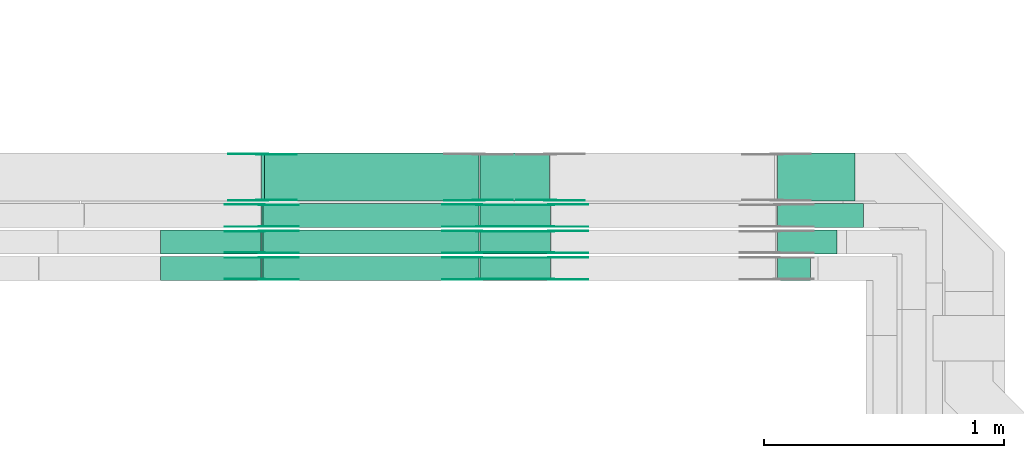
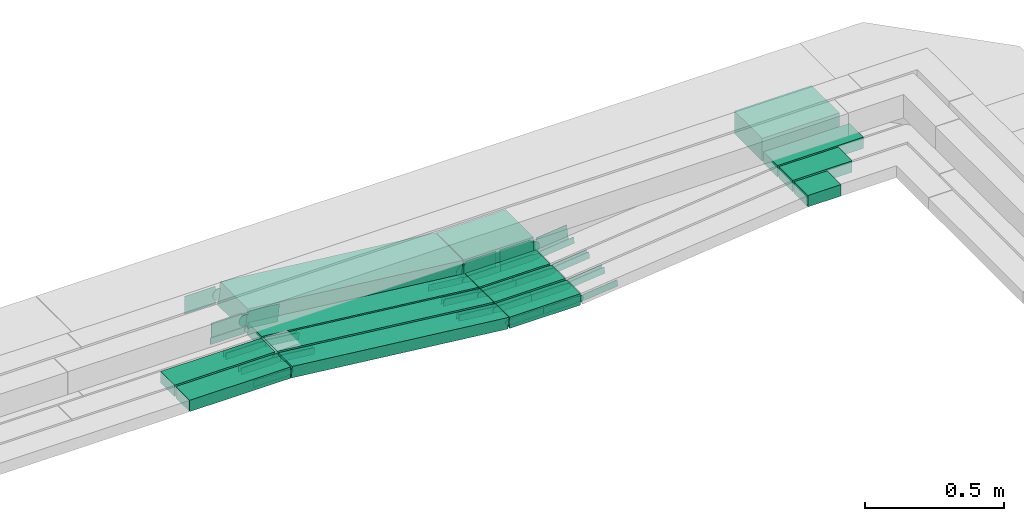
# One storey, part 18 of 32: 44 flow fittings, 14 flow segments.
"""IFC2X3 building model written with IfcOpenShell, lengths in millimetres."""

from ifc_helpers import new_model, entity, si_unit, converted_unit, derived_unit, direction, frame, frame_2d, origin, origin_2d_with_axis, place, context, subcontext, project, spatial, polyline, circle_curve, parameter, trimmed, segment, composite_curve, rectangle, outline, extrude, source, transform, mapped, material, type_object, type_shapes, element, save


model = new_model("IFC2X3")

# Units and contexts
model_context = context("Model", 3, precision=0.01, world=origin(), true_north=direction((6.12303176911189e-17, 1.0)))
body_context = subcontext(model_context, "Body", "Model", "MODEL_VIEW")
ifc_project = project(units=[si_unit("LENGTHUNIT", "METRE", prefix="MILLI"), si_unit("AREAUNIT", "SQUARE_METRE"), si_unit("VOLUMEUNIT", "CUBIC_METRE"), converted_unit("PLANEANGLEUNIT", "DEGREE", entity("IfcRatioMeasure", 0.0174532925199433), si_unit("PLANEANGLEUNIT", "RADIAN"), dimensions=[0, 0, 0, 0, 0, 0, 0]), si_unit("MASSUNIT", "GRAM", prefix="KILO"), derived_unit("MASSDENSITYUNIT", [(si_unit("MASSUNIT", "GRAM", prefix="KILO"), 1), (si_unit("LENGTHUNIT", "METRE"), -3)]), derived_unit("MOMENTOFINERTIAUNIT", [(si_unit("LENGTHUNIT", "METRE"), 4)]), si_unit("TIMEUNIT", "SECOND"), si_unit("FREQUENCYUNIT", "HERTZ"), si_unit("THERMODYNAMICTEMPERATUREUNIT", "DEGREE_CELSIUS"), derived_unit("THERMALTRANSMITTANCEUNIT", [(si_unit("MASSUNIT", "GRAM", prefix="KILO"), 1), (si_unit("THERMODYNAMICTEMPERATUREUNIT", "KELVIN"), -1), (si_unit("TIMEUNIT", "SECOND"), -3)]), derived_unit("VOLUMETRICFLOWRATEUNIT", [(si_unit("LENGTHUNIT", "METRE"), 3), (si_unit("TIMEUNIT", "SECOND"), -1)]), derived_unit("MASSFLOWRATEUNIT", [(si_unit("MASSUNIT", "GRAM", prefix="KILO"), 1), (si_unit("TIMEUNIT", "SECOND"), -1)]), derived_unit("ROTATIONALFREQUENCYUNIT", [(si_unit("TIMEUNIT", "SECOND"), -1)]), si_unit("ELECTRICCURRENTUNIT", "AMPERE"), si_unit("ELECTRICVOLTAGEUNIT", "VOLT"), si_unit("POWERUNIT", "WATT"), si_unit("FORCEUNIT", "NEWTON", prefix="KILO"), si_unit("ILLUMINANCEUNIT", "LUX"), si_unit("LUMINOUSFLUXUNIT", "LUMEN"), si_unit("LUMINOUSINTENSITYUNIT", "CANDELA"), derived_unit("USERDEFINED", [(si_unit("MASSUNIT", "GRAM", prefix="KILO"), -1), (si_unit("LENGTHUNIT", "METRE"), -2), (si_unit("TIMEUNIT", "SECOND"), 3), (si_unit("LUMINOUSFLUXUNIT", "LUMEN"), 1)]), derived_unit("LINEARVELOCITYUNIT", [(si_unit("LENGTHUNIT", "METRE"), 1), (si_unit("TIMEUNIT", "SECOND"), -1)]), si_unit("PRESSUREUNIT", "PASCAL"), derived_unit("USERDEFINED", [(si_unit("LENGTHUNIT", "METRE"), -2), (si_unit("MASSUNIT", "GRAM", prefix="KILO"), 1), (si_unit("TIMEUNIT", "SECOND"), -2)]), derived_unit("LINEARFORCEUNIT", [(si_unit("MASSUNIT", "GRAM", prefix="KILO"), 1), (si_unit("LENGTHUNIT", "METRE"), 1), (si_unit("TIMEUNIT", "SECOND"), -2), (si_unit("LENGTHUNIT", "METRE"), -1)]), derived_unit("PLANARFORCEUNIT", [(si_unit("MASSUNIT", "GRAM", prefix="KILO"), 1), (si_unit("LENGTHUNIT", "METRE"), 1), (si_unit("TIMEUNIT", "SECOND"), -2), (si_unit("LENGTHUNIT", "METRE"), -2)])], contexts=[model_context])

# Site, building, storey
site_placement = place(None, origin())
site = spatial("IfcSite", under=ifc_project, at=site_placement, CompositionType="ELEMENT")
building_placement = place(site_placement, origin())
building = spatial("IfcBuilding", under=site, at=building_placement, CompositionType="ELEMENT")
storey_placement = place(building_placement, frame((0.0, 0.0, 8100.0)))
storey = spatial("IfcBuildingStorey", under=building, at=storey_placement, CompositionType="ELEMENT", Elevation=8100.0)

# Flow segments
cable_carrier_segment_type = type_object("IfcCableCarrierSegmentType", PredefinedType="CABLETRAYSEGMENT")
flow_segment_1_placement = place(storey_placement, frame((42299.73, 9975.0, 2547.39)))
element("IfcFlowSegment", 1, at=flow_segment_1_placement, inside=storey, type_object=cable_carrier_segment_type, context=body_context, shape_type="SweptSolid", body=[
    extrude(rectangle(XDim=321.461786684155, YDim=200.000000000002, at=origin_2d_with_axis()), frame((160.73, 100.0, 0.0), z_axis=(0.0, 0.0, 1.0), x_axis=(-1.0, 0.0, 0.0)), (0.0, 0.0, 1.0), 99.9999999999989),
])
flow_segment_2_placement = place(storey_placement, frame((42299.91, 9865.0, 2544.96)))
element("IfcFlowSegment", 2, at=flow_segment_2_placement, inside=storey, type_object=cable_carrier_segment_type, context=body_context, shape_type="SweptSolid", body=[
    extrude(rectangle(XDim=357.279766558546, YDim=99.9999998664901, at=origin_2d_with_axis()), frame((178.64, 50.0, 0.02), z_axis=(0.000118881671848944, 0.0, 0.999999992933574), x_axis=(-0.999999992933574, 0.0, 0.000118881671848944)), (0.0, 0.0, 1.0), 49.9999999332506),
])
flow_segment_3_placement = place(storey_placement, frame((42299.73, 9755.0, 2546.32)))
element("IfcFlowSegment", 3, at=flow_segment_3_placement, inside=storey, type_object=cable_carrier_segment_type, context=body_context, shape_type="SweptSolid", body=[
    extrude(rectangle(XDim=247.461786684189, YDim=99.9999999999989, at=origin_2d_with_axis()), frame((123.73, 50.0, 0.0), z_axis=(0.0, 0.0, 1.0), x_axis=(-1.0, 0.0, 0.0)), (0.0, 0.0, 1.0), 50.0000000000016),
])
flow_segment_4_placement = place(storey_placement, frame((41059.78, 9645.0, 2446.67)))
element("IfcFlowSegment", 4, at=flow_segment_4_placement, inside=storey, type_object=cable_carrier_segment_type, context=body_context, shape_type="SweptSolid", body=[
    extrude(rectangle(XDim=294.865843634582, YDim=100.000000000001, at=origin_2d_with_axis()), frame((147.43, 50.0, 0.0), z_axis=(0.0, 0.0, 1.0), x_axis=(-1.0, 0.0, 0.0)), (0.0, 0.0, 1.0), 50.0000000000016),
])
flow_segment_5_placement = place(storey_placement, frame((42299.73, 9645.0, 2546.67)))
element("IfcFlowSegment", 5, at=flow_segment_5_placement, inside=storey, type_object=cable_carrier_segment_type, context=body_context, shape_type="SweptSolid", body=[
    extrude(rectangle(XDim=137.461786684197, YDim=100.000000000001, at=origin_2d_with_axis()), frame((68.73, 50.0, 0.0), z_axis=(0.0, 0.0, 1.0), x_axis=(-1.0, 0.0, 0.0)), (0.0, 0.0, 1.0), 49.9999999999995),
])
flow_segment_6_placement = place(storey_placement, frame((40151.55, 9645.0, 2447.11)))
element("IfcFlowSegment", 6, at=flow_segment_6_placement, inside=storey, type_object=cable_carrier_segment_type, context=body_context, shape_type="SweptSolid", body=[
    extrude(rectangle(XDim=50.0000000000012, YDim=100.000000000001, at=origin_2d_with_axis()), frame((2.74, 50.0, 124.24), z_axis=(0.993961132894519, 0.0, -0.109732703853703), x_axis=(0.109732703853703, 0.0, 0.993961132894519)), (0.0, 0.0, 1.0), 905.782469130237),
])
flow_segment_7_placement = place(storey_placement, frame((39730.39, 9645.0, 2546.63)))
element("IfcFlowSegment", 7, at=flow_segment_7_placement, inside=storey, type_object=cable_carrier_segment_type, context=body_context, shape_type="SweptSolid", body=[
    extrude(rectangle(XDim=418.730000005077, YDim=100.000000000001, at=origin_2d_with_axis()), frame((209.37, 50.0, 0.0), z_axis=(0.0, 0.0, 1.0), x_axis=(-1.0, 0.0, 0.0)), (0.0, 0.0, 1.0), 50.0000000000016),
])
flow_segment_8_placement = place(storey_placement, frame((41059.78, 9755.0, 2446.32)))
element("IfcFlowSegment", 8, at=flow_segment_8_placement, inside=storey, type_object=cable_carrier_segment_type, context=body_context, shape_type="SweptSolid", body=[
    extrude(rectangle(XDim=294.902694932285, YDim=99.9999999999989, at=origin_2d_with_axis()), frame((147.45, 50.0, 0.0), z_axis=(0.0, 0.0, 1.0), x_axis=(-1.0, 0.0, 0.0)), (0.0, 0.0, 1.0), 50.0000000000016),
])
flow_segment_9_placement = place(storey_placement, frame((40151.51, 9755.0, 2446.76)))
element("IfcFlowSegment", 9, at=flow_segment_9_placement, inside=storey, type_object=cable_carrier_segment_type, context=body_context, shape_type="SweptSolid", body=[
    extrude(rectangle(XDim=50.0000000000012, YDim=99.9999999999989, at=origin_2d_with_axis()), frame((2.74, 50.0, 124.25), z_axis=(0.993961132894519, 0.0, -0.109732703853703), x_axis=(0.109732703853703, 0.0, 0.993961132894519)), (0.0, 0.0, 1.0), 905.820480780093),
])
flow_segment_10_placement = place(storey_placement, frame((39730.39, 9755.0, 2546.29)))
element("IfcFlowSegment", 10, at=flow_segment_10_placement, inside=storey, type_object=cable_carrier_segment_type, context=body_context, shape_type="SweptSolid", body=[
    extrude(rectangle(XDim=418.692217902529, YDim=99.9999999999989, at=origin_2d_with_axis()), frame((209.35, 50.0, 0.0), z_axis=(0.0, 0.0, 1.0), x_axis=(-1.0, 0.0, 0.0)), (0.0, 0.0, 1.0), 50.0000000000038),
])
flow_segment_11_placement = place(storey_placement, frame((41059.6, 9865.0, 2444.98)))
element("IfcFlowSegment", 11, at=flow_segment_11_placement, inside=storey, type_object=cable_carrier_segment_type, context=body_context, shape_type="SweptSolid", body=[
    extrude(rectangle(XDim=295.052090595501, YDim=99.9999999999989, at=origin_2d_with_axis()), frame((147.53, 50.0, 0.0), z_axis=(0.0, 0.0, 1.0), x_axis=(-1.0, 0.0, 0.0)), (0.0, 0.0, 1.0), 50.0000000000016),
])
flow_segment_12_placement = place(storey_placement, frame((40151.55, 9865.0, 2445.42)))
element("IfcFlowSegment", 12, at=flow_segment_12_placement, inside=storey, type_object=cable_carrier_segment_type, context=body_context, shape_type="SweptSolid", body=[
    extrude(rectangle(XDim=50.0000000000012, YDim=99.9999999999989, at=origin_2d_with_axis()), frame((2.74, 50.0, 124.22), z_axis=(0.993961132894519, 0.0, -0.109732703853703), x_axis=(0.109732703853703, 0.0, 0.993961132894519)), (0.0, 0.0, 1.0), 905.595090615417),
])
flow_segment_13_placement = place(storey_placement, frame((41059.78, 9975.0, 2447.11)))
element("IfcFlowSegment", 13, at=flow_segment_13_placement, inside=storey, type_object=cable_carrier_segment_type, context=body_context, shape_type="SweptSolid", body=[
    extrude(rectangle(XDim=289.500216036665, YDim=199.999999999998, at=origin_2d_with_axis()), frame((144.75, 100.0, 0.0), z_axis=(0.0, 0.0, 1.0), x_axis=(-1.0, 0.0, 0.0)), (0.0, 0.0, 1.0), 99.9999999999989),
])
flow_segment_14_placement = place(storey_placement, frame((40151.57, 9975.0, 2447.84)))
element("IfcFlowSegment", 14, at=flow_segment_14_placement, inside=storey, type_object=cable_carrier_segment_type, context=body_context, shape_type="SweptSolid", body=[
    extrude(rectangle(XDim=99.9999999999982, YDim=200.000000000002, at=origin_2d_with_axis()), frame((5.49, 100.0, 148.48), z_axis=(0.993961132894518, 0.0, -0.109732703853708), x_axis=(0.109732703853708, 0.0, 0.993961132894518)), (0.0, 0.0, 1.0), 900.246310655869),
])

# Flow fittings
ifc_material = material(Name="G")
cable_carrier_fitting_type_1 = type_object("IfcCableCarrierFittingType", PredefinedType="NOTDEFINED", material=ifc_material)
shared_shape_1 = source(origin(), body_context, "Body", "SweptSolid", [
    extrude(outline(composite_curve([segment(trimmed(circle_curve(frame_2d((-44.59, 0.0), x_axis=(1.0, 0.0)), 12.5), [parameter(90.0000000000007)], [parameter(270.0)], True, "PARAMETER"), True, "CONTINUOUS"), segment(polyline([(-44.59, -12.5), (-33.09, -12.5)]), True, "CONTINUOUS"), segment(polyline([(-33.09, -12.5), (-31.23, -14.5)]), True, "CONTINUOUS"), segment(polyline([(-31.23, -14.5), (108.91, -14.5)]), True, "CONTINUOUS"), segment(polyline([(108.91, -14.5), (108.91, 14.5)]), True, "CONTINUOUS"), segment(polyline([(108.91, 14.5), (-31.23, 14.5)]), True, "CONTINUOUS"), segment(polyline([(-31.23, 14.5), (-33.09, 12.5)]), True, "CONTINUOUS"), segment(polyline([(-33.09, 12.5), (-44.59, 12.5)]), True, "CONTINUOUS")], self_intersect=False)), frame((44.59, 0.0, 0.0), z_axis=(0.0, 0.0, -1.0), x_axis=(1.0, 0.0, 0.0)), (0.0, 0.0, -1.0), 2.0),
])
type_shapes(cable_carrier_fitting_type_1, [shared_shape_1])
flow_fitting_1_placement = place(storey_placement, frame((41357.19, 9649.54, 2471.67), z_axis=(0.0, -1.0, 0.0), x_axis=(0.994388913179106, 0.0, 0.105786054593584)))
element("IfcFlowFitting", 15, at=flow_fitting_1_placement, inside=storey, type_object=cable_carrier_fitting_type_1, material=ifc_material, context=body_context, shape_type="MappedRepresentation", body=[
    mapped(shared_shape_1, transform((0.0, 0.0, 0.0), scale=1.0)),
])
cable_carrier_fitting_type_2 = type_object("IfcCableCarrierFittingType", PredefinedType="NOTDEFINED", material=ifc_material)
type_shapes(cable_carrier_fitting_type_2, [shared_shape_1])
flow_fitting_2_placement = place(storey_placement, frame((41357.19, 9738.46, 2471.67), z_axis=(0.0, 1.0, 0.0), x_axis=(-1.0, 0.0, 0.0)))
element("IfcFlowFitting", 16, at=flow_fitting_2_placement, inside=storey, type_object=cable_carrier_fitting_type_2, material=ifc_material, context=body_context, shape_type="MappedRepresentation", body=[
    mapped(shared_shape_1, transform((0.0, 0.0, 0.0), scale=1.0)),
])
flow_fitting_3_placement = place(storey_placement, frame((41057.19, 9740.46, 2471.67), z_axis=(0.0, 1.0, 0.0), x_axis=(-0.993961132894515, 0.0, 0.10973270385374)))
element("IfcFlowFitting", 17, at=flow_fitting_3_placement, inside=storey, type_object=cable_carrier_fitting_type_1, material=ifc_material, context=body_context, shape_type="MappedRepresentation", body=[
    mapped(shared_shape_1, transform((0.0, 0.0, 0.0), scale=1.0)),
])
flow_fitting_4_placement = place(storey_placement, frame((41057.19, 9651.54, 2471.67), z_axis=(0.0, -1.0, 0.0), x_axis=(1.0, 0.0, 0.0)))
element("IfcFlowFitting", 18, at=flow_fitting_4_placement, inside=storey, type_object=cable_carrier_fitting_type_2, material=ifc_material, context=body_context, shape_type="MappedRepresentation", body=[
    mapped(shared_shape_1, transform((0.0, 0.0, 0.0), scale=1.0)),
])
flow_fitting_5_placement = place(storey_placement, frame((40151.72, 9740.46, 2571.63), z_axis=(0.0, 1.0, 0.0), x_axis=(0.993961132894515, 0.0, -0.10973270385374)))
element("IfcFlowFitting", 19, at=flow_fitting_5_placement, inside=storey, type_object=cable_carrier_fitting_type_1, material=ifc_material, context=body_context, shape_type="MappedRepresentation", body=[
    mapped(shared_shape_1, transform((0.0, 0.0, 0.0), scale=1.0)),
])
flow_fitting_6_placement = place(storey_placement, frame((40151.72, 9651.54, 2571.63), z_axis=(0.0, -1.0, 0.0), x_axis=(-1.0, 0.0, 0.0)))
element("IfcFlowFitting", 20, at=flow_fitting_6_placement, inside=storey, type_object=cable_carrier_fitting_type_2, material=ifc_material, context=body_context, shape_type="MappedRepresentation", body=[
    mapped(shared_shape_1, transform((0.0, 0.0, 0.0), scale=1.0)),
])
flow_fitting_7_placement = place(storey_placement, frame((41357.23, 9759.54, 2471.32), z_axis=(0.0, -1.0, 0.0), x_axis=(0.994388913179106, 0.0, 0.105786054593584)))
element("IfcFlowFitting", 21, at=flow_fitting_7_placement, inside=storey, type_object=cable_carrier_fitting_type_1, material=ifc_material, context=body_context, shape_type="MappedRepresentation", body=[
    mapped(shared_shape_1, transform((0.0, 0.0, 0.0), scale=1.0)),
])
flow_fitting_8_placement = place(storey_placement, frame((41357.23, 9848.46, 2471.32), z_axis=(0.0, 1.0, 0.0), x_axis=(-1.0, 0.0, 0.0)))
element("IfcFlowFitting", 22, at=flow_fitting_8_placement, inside=storey, type_object=cable_carrier_fitting_type_2, material=ifc_material, context=body_context, shape_type="MappedRepresentation", body=[
    mapped(shared_shape_1, transform((0.0, 0.0, 0.0), scale=1.0)),
])
flow_fitting_9_placement = place(storey_placement, frame((41057.19, 9850.46, 2471.32), z_axis=(0.0, 1.0, 0.0), x_axis=(-0.993961132894515, 0.0, 0.10973270385374)))
element("IfcFlowFitting", 23, at=flow_fitting_9_placement, inside=storey, type_object=cable_carrier_fitting_type_1, material=ifc_material, context=body_context, shape_type="MappedRepresentation", body=[
    mapped(shared_shape_1, transform((0.0, 0.0, 0.0), scale=1.0)),
])
flow_fitting_10_placement = place(storey_placement, frame((41057.19, 9761.54, 2471.32), z_axis=(0.0, -1.0, 0.0), x_axis=(1.0, 0.0, 0.0)))
element("IfcFlowFitting", 24, at=flow_fitting_10_placement, inside=storey, type_object=cable_carrier_fitting_type_2, material=ifc_material, context=body_context, shape_type="MappedRepresentation", body=[
    mapped(shared_shape_1, transform((0.0, 0.0, 0.0), scale=1.0)),
])
flow_fitting_11_placement = place(storey_placement, frame((40151.68, 9850.46, 2571.29), z_axis=(0.0, 1.0, 0.0), x_axis=(0.993961132894515, 0.0, -0.10973270385374)))
element("IfcFlowFitting", 25, at=flow_fitting_11_placement, inside=storey, type_object=cable_carrier_fitting_type_1, material=ifc_material, context=body_context, shape_type="MappedRepresentation", body=[
    mapped(shared_shape_1, transform((0.0, 0.0, 0.0), scale=1.0)),
])
flow_fitting_12_placement = place(storey_placement, frame((40151.68, 9761.54, 2571.29), z_axis=(0.0, -1.0, 0.0), x_axis=(-1.0, 0.0, 0.0)))
element("IfcFlowFitting", 26, at=flow_fitting_12_placement, inside=storey, type_object=cable_carrier_fitting_type_2, material=ifc_material, context=body_context, shape_type="MappedRepresentation", body=[
    mapped(shared_shape_1, transform((0.0, 0.0, 0.0), scale=1.0)),
])
flow_fitting_13_placement = place(storey_placement, frame((41357.19, 9869.54, 2469.98), z_axis=(0.0, -1.0, 0.0), x_axis=(0.994388913179106, 0.0, 0.105786054593584)))
element("IfcFlowFitting", 27, at=flow_fitting_13_placement, inside=storey, type_object=cable_carrier_fitting_type_1, material=ifc_material, context=body_context, shape_type="MappedRepresentation", body=[
    mapped(shared_shape_1, transform((0.0, 0.0, 0.0), scale=1.0)),
])
flow_fitting_14_placement = place(storey_placement, frame((41357.19, 9958.46, 2469.98), z_axis=(0.0, 1.0, 0.0), x_axis=(-1.0, 0.0, 0.0)))
element("IfcFlowFitting", 28, at=flow_fitting_14_placement, inside=storey, type_object=cable_carrier_fitting_type_2, material=ifc_material, context=body_context, shape_type="MappedRepresentation", body=[
    mapped(shared_shape_1, transform((0.0, 0.0, 0.0), scale=1.0)),
])
flow_fitting_15_placement = place(storey_placement, frame((41057.0, 9960.46, 2469.98), z_axis=(0.0, 1.0, 0.0), x_axis=(-0.993961132894515, 0.0, 0.10973270385374)))
element("IfcFlowFitting", 29, at=flow_fitting_15_placement, inside=storey, type_object=cable_carrier_fitting_type_1, material=ifc_material, context=body_context, shape_type="MappedRepresentation", body=[
    mapped(shared_shape_1, transform((0.0, 0.0, 0.0), scale=1.0)),
])
flow_fitting_16_placement = place(storey_placement, frame((41057.0, 9871.54, 2469.98), z_axis=(0.0, -1.0, 0.0), x_axis=(1.0, 0.0, 0.0)))
element("IfcFlowFitting", 30, at=flow_fitting_16_placement, inside=storey, type_object=cable_carrier_fitting_type_2, material=ifc_material, context=body_context, shape_type="MappedRepresentation", body=[
    mapped(shared_shape_1, transform((0.0, 0.0, 0.0), scale=1.0)),
])
flow_fitting_17_placement = place(storey_placement, frame((40151.72, 9869.54, 2569.93), z_axis=(0.0, -1.0, 0.0), x_axis=(-1.0, 0.0, 0.0)))
element("IfcFlowFitting", 31, at=flow_fitting_17_placement, inside=storey, type_object=cable_carrier_fitting_type_1, material=ifc_material, context=body_context, shape_type="MappedRepresentation", body=[
    mapped(shared_shape_1, transform((0.0, 0.0, 0.0), scale=1.0)),
])
flow_fitting_18_placement = place(storey_placement, frame((40151.72, 9958.46, 2569.93), z_axis=(0.0, 1.0, 0.0), x_axis=(0.993961132894516, 0.0, -0.109732703853733)))
element("IfcFlowFitting", 32, at=flow_fitting_18_placement, inside=storey, type_object=cable_carrier_fitting_type_2, material=ifc_material, context=body_context, shape_type="MappedRepresentation", body=[
    mapped(shared_shape_1, transform((0.0, 0.0, 0.0), scale=1.0)),
])
cable_carrier_fitting_type_3 = type_object("IfcCableCarrierFittingType", PredefinedType="NOTDEFINED", material=ifc_material)
shared_shape_2 = source(origin(), body_context, "Body", "SweptSolid", [
    extrude(outline(composite_curve([segment(trimmed(circle_curve(frame_2d((-44.59, 0.0), x_axis=(1.0, 0.0)), 12.5), [parameter(90.0000000000007)], [parameter(270.0)], True, "PARAMETER"), True, "CONTINUOUS"), segment(polyline([(-44.59, -12.5), (-33.09, -12.5)]), True, "CONTINUOUS"), segment(polyline([(-33.09, -12.5), (-31.23, -14.5)]), True, "CONTINUOUS"), segment(polyline([(-31.23, -14.5), (108.91, -14.5)]), True, "CONTINUOUS"), segment(polyline([(108.91, -14.5), (108.91, 14.5)]), True, "CONTINUOUS"), segment(polyline([(108.91, 14.5), (-31.23, 14.5)]), True, "CONTINUOUS"), segment(polyline([(-31.23, 14.5), (-33.09, 12.5)]), True, "CONTINUOUS"), segment(polyline([(-33.09, 12.5), (-44.59, 12.5)]), True, "CONTINUOUS")], self_intersect=False)), frame((44.59, 0.0, 0.0)), (0.0, 0.0, 1.0), 2.0),
])
type_shapes(cable_carrier_fitting_type_3, [shared_shape_2])
flow_fitting_19_placement = place(storey_placement, frame((41357.19, 9740.46, 2471.67), z_axis=(0.0, 1.0, 0.0), x_axis=(0.994388913179106, 0.0, 0.105786054593584)))
element("IfcFlowFitting", 33, at=flow_fitting_19_placement, inside=storey, type_object=cable_carrier_fitting_type_3, material=ifc_material, context=body_context, shape_type="MappedRepresentation", body=[
    mapped(shared_shape_2, transform((0.0, 0.0, 0.0), scale=1.0)),
])
cable_carrier_fitting_type_4 = type_object("IfcCableCarrierFittingType", PredefinedType="NOTDEFINED", material=ifc_material)
type_shapes(cable_carrier_fitting_type_4, [shared_shape_2])
flow_fitting_20_placement = place(storey_placement, frame((41357.19, 9651.54, 2471.67), z_axis=(0.0, -1.0, 0.0), x_axis=(-1.0, 0.0, 0.0)))
element("IfcFlowFitting", 34, at=flow_fitting_20_placement, inside=storey, type_object=cable_carrier_fitting_type_4, material=ifc_material, context=body_context, shape_type="MappedRepresentation", body=[
    mapped(shared_shape_2, transform((0.0, 0.0, 0.0), scale=1.0)),
])
flow_fitting_21_placement = place(storey_placement, frame((41057.19, 9649.54, 2471.67), z_axis=(0.0, -1.0, 0.0), x_axis=(-0.993961132894515, 0.0, 0.10973270385374)))
element("IfcFlowFitting", 35, at=flow_fitting_21_placement, inside=storey, type_object=cable_carrier_fitting_type_3, material=ifc_material, context=body_context, shape_type="MappedRepresentation", body=[
    mapped(shared_shape_2, transform((0.0, 0.0, 0.0), scale=1.0)),
])
flow_fitting_22_placement = place(storey_placement, frame((41057.19, 9738.46, 2471.67), z_axis=(0.0, 1.0, 0.0), x_axis=(1.0, 0.0, 0.0)))
element("IfcFlowFitting", 36, at=flow_fitting_22_placement, inside=storey, type_object=cable_carrier_fitting_type_4, material=ifc_material, context=body_context, shape_type="MappedRepresentation", body=[
    mapped(shared_shape_2, transform((0.0, 0.0, 0.0), scale=1.0)),
])
flow_fitting_23_placement = place(storey_placement, frame((40151.72, 9649.54, 2571.63), z_axis=(0.0, -1.0, 0.0), x_axis=(0.993961132894515, 0.0, -0.10973270385374)))
element("IfcFlowFitting", 37, at=flow_fitting_23_placement, inside=storey, type_object=cable_carrier_fitting_type_3, material=ifc_material, context=body_context, shape_type="MappedRepresentation", body=[
    mapped(shared_shape_2, transform((0.0, 0.0, 0.0), scale=1.0)),
])
flow_fitting_24_placement = place(storey_placement, frame((40151.72, 9738.46, 2571.63), z_axis=(0.0, 1.0, 0.0), x_axis=(-1.0, 0.0, 0.0)))
element("IfcFlowFitting", 38, at=flow_fitting_24_placement, inside=storey, type_object=cable_carrier_fitting_type_4, material=ifc_material, context=body_context, shape_type="MappedRepresentation", body=[
    mapped(shared_shape_2, transform((0.0, 0.0, 0.0), scale=1.0)),
])
flow_fitting_25_placement = place(storey_placement, frame((41357.23, 9850.46, 2471.32), z_axis=(0.0, 1.0, 0.0), x_axis=(0.994388913179106, 0.0, 0.105786054593584)))
element("IfcFlowFitting", 39, at=flow_fitting_25_placement, inside=storey, type_object=cable_carrier_fitting_type_3, material=ifc_material, context=body_context, shape_type="MappedRepresentation", body=[
    mapped(shared_shape_2, transform((0.0, 0.0, 0.0), scale=1.0)),
])
flow_fitting_26_placement = place(storey_placement, frame((41357.23, 9761.54, 2471.32), z_axis=(0.0, -1.0, 0.0), x_axis=(-1.0, 0.0, 0.0)))
element("IfcFlowFitting", 40, at=flow_fitting_26_placement, inside=storey, type_object=cable_carrier_fitting_type_4, material=ifc_material, context=body_context, shape_type="MappedRepresentation", body=[
    mapped(shared_shape_2, transform((0.0, 0.0, 0.0), scale=1.0)),
])
flow_fitting_27_placement = place(storey_placement, frame((41057.19, 9759.54, 2471.32), z_axis=(0.0, -1.0, 0.0), x_axis=(-0.993961132894515, 0.0, 0.10973270385374)))
element("IfcFlowFitting", 41, at=flow_fitting_27_placement, inside=storey, type_object=cable_carrier_fitting_type_3, material=ifc_material, context=body_context, shape_type="MappedRepresentation", body=[
    mapped(shared_shape_2, transform((0.0, 0.0, 0.0), scale=1.0)),
])
flow_fitting_28_placement = place(storey_placement, frame((41057.19, 9848.46, 2471.32), z_axis=(0.0, 1.0, 0.0), x_axis=(1.0, 0.0, 0.0)))
element("IfcFlowFitting", 42, at=flow_fitting_28_placement, inside=storey, type_object=cable_carrier_fitting_type_4, material=ifc_material, context=body_context, shape_type="MappedRepresentation", body=[
    mapped(shared_shape_2, transform((0.0, 0.0, 0.0), scale=1.0)),
])
flow_fitting_29_placement = place(storey_placement, frame((40151.68, 9759.54, 2571.29), z_axis=(0.0, -1.0, 0.0), x_axis=(0.993961132894515, 0.0, -0.10973270385374)))
element("IfcFlowFitting", 43, at=flow_fitting_29_placement, inside=storey, type_object=cable_carrier_fitting_type_3, material=ifc_material, context=body_context, shape_type="MappedRepresentation", body=[
    mapped(shared_shape_2, transform((0.0, 0.0, 0.0), scale=1.0)),
])
flow_fitting_30_placement = place(storey_placement, frame((40151.68, 9848.46, 2571.29), z_axis=(0.0, 1.0, 0.0), x_axis=(-1.0, 0.0, 0.0)))
element("IfcFlowFitting", 44, at=flow_fitting_30_placement, inside=storey, type_object=cable_carrier_fitting_type_4, material=ifc_material, context=body_context, shape_type="MappedRepresentation", body=[
    mapped(shared_shape_2, transform((0.0, 0.0, 0.0), scale=1.0)),
])
flow_fitting_31_placement = place(storey_placement, frame((41357.19, 9960.46, 2469.98), z_axis=(0.0, 1.0, 0.0), x_axis=(0.994388913179106, 0.0, 0.105786054593584)))
element("IfcFlowFitting", 45, at=flow_fitting_31_placement, inside=storey, type_object=cable_carrier_fitting_type_3, material=ifc_material, context=body_context, shape_type="MappedRepresentation", body=[
    mapped(shared_shape_2, transform((0.0, 0.0, 0.0), scale=1.0)),
])
flow_fitting_32_placement = place(storey_placement, frame((41357.19, 9871.54, 2469.98), z_axis=(0.0, -1.0, 0.0), x_axis=(-1.0, 0.0, 0.0)))
element("IfcFlowFitting", 46, at=flow_fitting_32_placement, inside=storey, type_object=cable_carrier_fitting_type_4, material=ifc_material, context=body_context, shape_type="MappedRepresentation", body=[
    mapped(shared_shape_2, transform((0.0, 0.0, 0.0), scale=1.0)),
])
flow_fitting_33_placement = place(storey_placement, frame((41057.0, 9869.54, 2469.98), z_axis=(0.0, -1.0, 0.0), x_axis=(-0.993961132894515, 0.0, 0.10973270385374)))
element("IfcFlowFitting", 47, at=flow_fitting_33_placement, inside=storey, type_object=cable_carrier_fitting_type_3, material=ifc_material, context=body_context, shape_type="MappedRepresentation", body=[
    mapped(shared_shape_2, transform((0.0, 0.0, 0.0), scale=1.0)),
])
flow_fitting_34_placement = place(storey_placement, frame((41057.0, 9958.46, 2469.98), z_axis=(0.0, 1.0, 0.0), x_axis=(1.0, 0.0, 0.0)))
element("IfcFlowFitting", 48, at=flow_fitting_34_placement, inside=storey, type_object=cable_carrier_fitting_type_4, material=ifc_material, context=body_context, shape_type="MappedRepresentation", body=[
    mapped(shared_shape_2, transform((0.0, 0.0, 0.0), scale=1.0)),
])
flow_fitting_35_placement = place(storey_placement, frame((40151.72, 9960.46, 2569.93), z_axis=(0.0, 1.0, 0.0), x_axis=(-1.0, 0.0, 0.0)))
element("IfcFlowFitting", 49, at=flow_fitting_35_placement, inside=storey, type_object=cable_carrier_fitting_type_3, material=ifc_material, context=body_context, shape_type="MappedRepresentation", body=[
    mapped(shared_shape_2, transform((0.0, 0.0, 0.0), scale=1.0)),
])
flow_fitting_36_placement = place(storey_placement, frame((40151.72, 9871.54, 2569.93), z_axis=(0.0, -1.0, 0.0), x_axis=(0.993961132894516, 0.0, -0.109732703853733)))
element("IfcFlowFitting", 50, at=flow_fitting_36_placement, inside=storey, type_object=cable_carrier_fitting_type_4, material=ifc_material, context=body_context, shape_type="MappedRepresentation", body=[
    mapped(shared_shape_2, transform((0.0, 0.0, 0.0), scale=1.0)),
])
cable_carrier_fitting_type_5 = type_object("IfcCableCarrierFittingType", PredefinedType="NOTDEFINED", material=ifc_material)
shared_shape_3 = source(origin(), body_context, "Body", "SweptSolid", [
    extrude(outline(composite_curve([segment(trimmed(circle_curve(frame_2d((-41.47, 0.0), x_axis=(1.0, 0.0)), 25.0), [parameter(90.0000000000007)], [parameter(270.0)], True, "PARAMETER"), True, "CONTINUOUS"), segment(polyline([(-41.47, -25.0), (-29.97, -25.0)]), True, "CONTINUOUS"), segment(polyline([(-29.97, -25.0), (-28.1, -38.5)]), True, "CONTINUOUS"), segment(polyline([(-28.1, -38.5), (99.53, -38.5)]), True, "CONTINUOUS"), segment(polyline([(99.53, -38.5), (99.53, 38.5)]), True, "CONTINUOUS"), segment(polyline([(99.53, 38.5), (-28.1, 38.5)]), True, "CONTINUOUS"), segment(polyline([(-28.1, 38.5), (-29.97, 25.0)]), True, "CONTINUOUS"), segment(polyline([(-29.97, 25.0), (-41.47, 25.0)]), True, "CONTINUOUS")], self_intersect=False)), frame((41.47, 0.0, 0.0), z_axis=(0.0, 0.0, -1.0), x_axis=(1.0, 0.0, 0.0)), (0.0, 0.0, -1.0), 2.0),
])
type_shapes(cable_carrier_fitting_type_5, [shared_shape_3])
flow_fitting_37_placement = place(storey_placement, frame((41353.15, 9979.54, 2497.11), z_axis=(0.0, -1.0, 0.0), x_axis=(0.994388913179106, 0.0, 0.105786054593584)))
element("IfcFlowFitting", 51, at=flow_fitting_37_placement, inside=storey, type_object=cable_carrier_fitting_type_5, material=ifc_material, context=body_context, shape_type="MappedRepresentation", body=[
    mapped(shared_shape_3, transform((0.0, 0.0, 0.0), scale=1.0)),
])
cable_carrier_fitting_type_6 = type_object("IfcCableCarrierFittingType", PredefinedType="NOTDEFINED", material=ifc_material)
type_shapes(cable_carrier_fitting_type_6, [shared_shape_3])
flow_fitting_38_placement = place(storey_placement, frame((41055.81, 9981.54, 2497.11), z_axis=(0.0, -1.0, 0.0), x_axis=(1.0, 0.0, 0.0)))
element("IfcFlowFitting", 52, at=flow_fitting_38_placement, inside=storey, type_object=cable_carrier_fitting_type_6, material=ifc_material, context=body_context, shape_type="MappedRepresentation", body=[
    mapped(shared_shape_3, transform((0.0, 0.0, 0.0), scale=1.0)),
])
flow_fitting_39_placement = place(storey_placement, frame((40153.11, 9979.54, 2596.76), z_axis=(0.0, -1.0, 0.0), x_axis=(-0.99999998513436, 0.0, 0.00017242761067629)))
element("IfcFlowFitting", 53, at=flow_fitting_39_placement, inside=storey, type_object=cable_carrier_fitting_type_5, material=ifc_material, context=body_context, shape_type="MappedRepresentation", body=[
    mapped(shared_shape_3, transform((0.0, 0.0, 0.0), scale=1.0)),
])
flow_fitting_40_placement = place(storey_placement, frame((40153.11, 10168.46, 2596.76), z_axis=(0.0, 1.0, 0.0), x_axis=(0.993961132894515, 0.0, -0.109732703853739)))
element("IfcFlowFitting", 54, at=flow_fitting_40_placement, inside=storey, type_object=cable_carrier_fitting_type_6, material=ifc_material, context=body_context, shape_type="MappedRepresentation", body=[
    mapped(shared_shape_3, transform((0.0, 0.0, 0.0), scale=1.0)),
])
cable_carrier_fitting_type_7 = type_object("IfcCableCarrierFittingType", PredefinedType="NOTDEFINED", material=ifc_material)
shared_shape_4 = source(origin(), body_context, "Body", "SweptSolid", [
    extrude(outline(composite_curve([segment(trimmed(circle_curve(frame_2d((-41.47, 0.0), x_axis=(1.0, 0.0)), 25.0), [parameter(90.0000000000007)], [parameter(270.0)], True, "PARAMETER"), True, "CONTINUOUS"), segment(polyline([(-41.47, -25.0), (-29.97, -25.0)]), True, "CONTINUOUS"), segment(polyline([(-29.97, -25.0), (-28.1, -38.5)]), True, "CONTINUOUS"), segment(polyline([(-28.1, -38.5), (99.53, -38.5)]), True, "CONTINUOUS"), segment(polyline([(99.53, -38.5), (99.53, 38.5)]), True, "CONTINUOUS"), segment(polyline([(99.53, 38.5), (-28.1, 38.5)]), True, "CONTINUOUS"), segment(polyline([(-28.1, 38.5), (-29.97, 25.0)]), True, "CONTINUOUS"), segment(polyline([(-29.97, 25.0), (-41.47, 25.0)]), True, "CONTINUOUS")], self_intersect=False)), frame((41.47, 0.0, 0.0)), (0.0, 0.0, 1.0), 2.0),
])
type_shapes(cable_carrier_fitting_type_7, [shared_shape_4])
flow_fitting_41_placement = place(storey_placement, frame((41353.15, 9981.54, 2497.11), z_axis=(0.0, -1.0, 0.0), x_axis=(-1.0, 0.0, 0.0)))
element("IfcFlowFitting", 55, at=flow_fitting_41_placement, inside=storey, type_object=cable_carrier_fitting_type_7, material=ifc_material, context=body_context, shape_type="MappedRepresentation", body=[
    mapped(shared_shape_4, transform((0.0, 0.0, 0.0), scale=1.0)),
])
cable_carrier_fitting_type_8 = type_object("IfcCableCarrierFittingType", PredefinedType="NOTDEFINED", material=ifc_material)
type_shapes(cable_carrier_fitting_type_8, [shared_shape_4])
for number, where, z_axis, x_axis in (
    (56, (41055.81, 9979.54, 2497.11), (0.0, -1.0, 0.0), (-0.993961132894515, 0.0, 0.10973270385374)),
    (57, (40153.11, 10170.46, 2596.76), (0.0, 1.0, 0.0), (-0.99999998513436, 0.0, 0.00017242761067629)),
):
    element("IfcFlowFitting", number, at=place(storey_placement, frame(where, z_axis=z_axis, x_axis=x_axis)), inside=storey, type_object=cable_carrier_fitting_type_8, material=ifc_material, context=body_context, shape_type="MappedRepresentation", body=[
        mapped(shared_shape_4, transform((0.0, 0.0, 0.0), scale=1.0)),
    ])
flow_fitting_42_placement = place(storey_placement, frame((40153.11, 9981.54, 2596.76), z_axis=(0.0, -1.0, 0.0), x_axis=(0.993961132894515, 0.0, -0.109732703853739)))
element("IfcFlowFitting", 58, at=flow_fitting_42_placement, inside=storey, type_object=cable_carrier_fitting_type_7, material=ifc_material, context=body_context, shape_type="MappedRepresentation", body=[
    mapped(shared_shape_4, transform((0.0, 0.0, 0.0), scale=1.0)),
])

save(model, "model.ifc")
